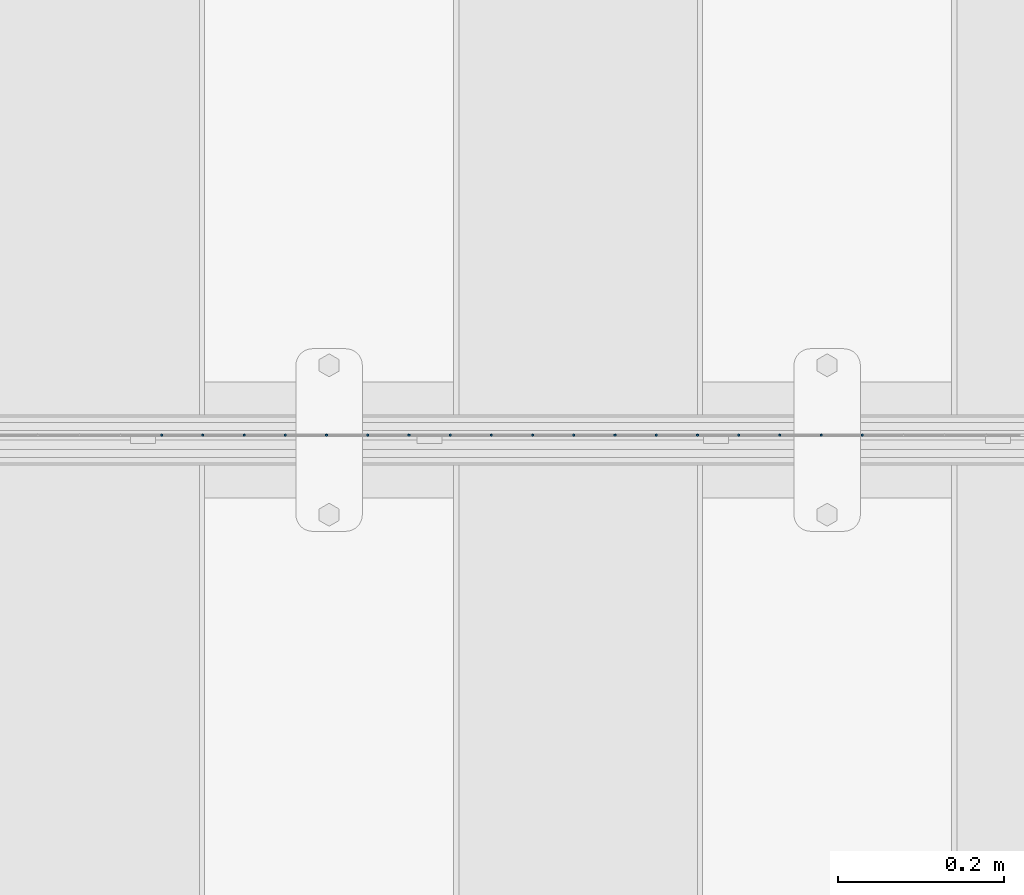
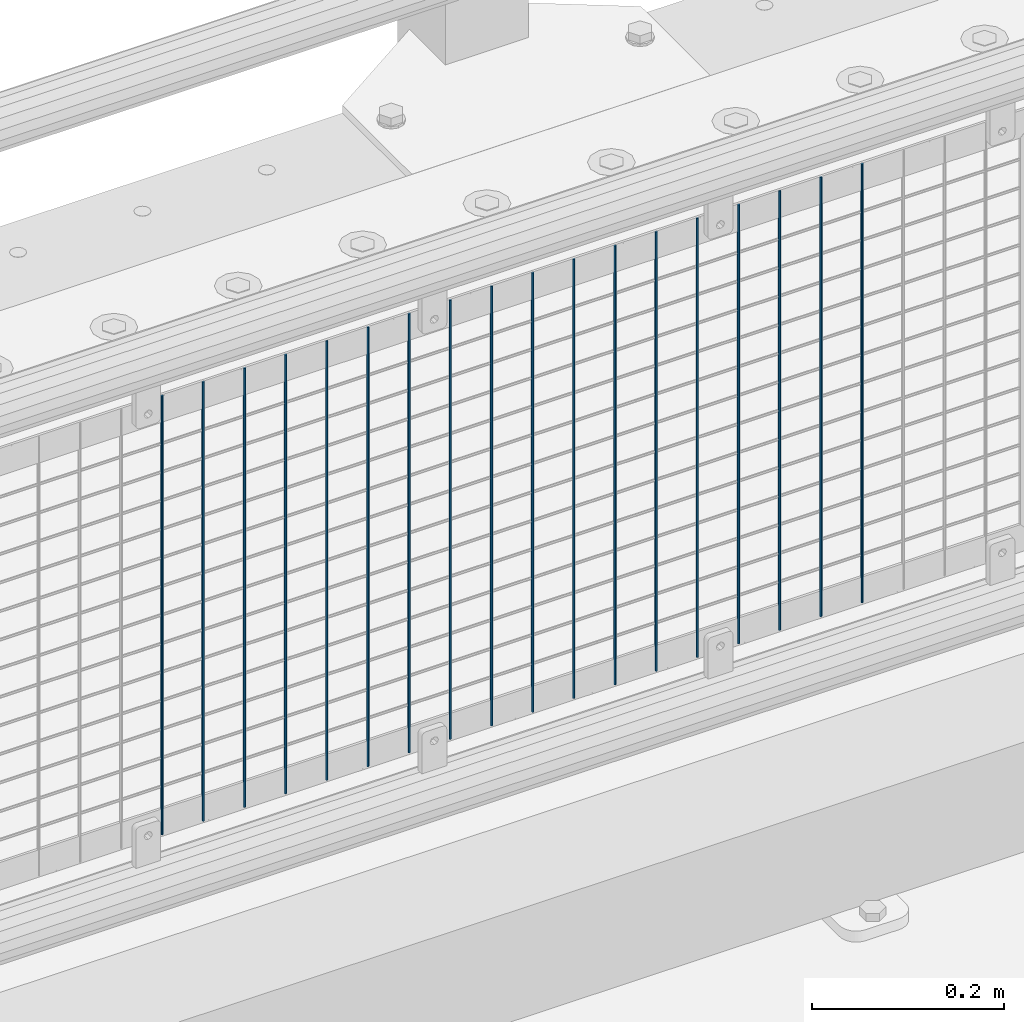
# One storey, part 69 of 247: 18 columns.
"""IFC2X3 building model written with IfcOpenShell, lengths in millimetres."""

from ifc_helpers import new_model, si_unit, frame, origin_with_axes, place, context, subcontext, project, spatial, faceted_brep, material, type_object, element, save


model = new_model("IFC2X3")

# Units and contexts
model_context = context("Model", 3, precision=1e-05, world=origin_with_axes())
body_context = subcontext(model_context, "Body", "Model", "MODEL_VIEW")
ifc_project = project(units=[si_unit("LENGTHUNIT", "METRE", prefix="MILLI"), si_unit("AREAUNIT", "SQUARE_METRE"), si_unit("VOLUMEUNIT", "CUBIC_METRE"), si_unit("MASSUNIT", "GRAM", prefix="KILO"), si_unit("TIMEUNIT", "SECOND"), si_unit("PLANEANGLEUNIT", "RADIAN"), si_unit("SOLIDANGLEUNIT", "STERADIAN"), si_unit("THERMODYNAMICTEMPERATUREUNIT", "DEGREE_CELSIUS"), si_unit("LUMINOUSINTENSITYUNIT", "LUMEN")], contexts=[model_context])

# Site, building, storey
site_placement = place(None, origin_with_axes())
site = spatial("IfcSite", under=ifc_project, at=site_placement, CompositionType="ELEMENT")
building_placement = place(site_placement, origin_with_axes())
building = spatial("IfcBuilding", under=site, at=building_placement, Name="Standard", CompositionType="ELEMENT")
storey_placement = place(building_placement, origin_with_axes())
storey = spatial("IfcBuildingStorey", under=building, at=storey_placement, Name="Undefined", CompositionType="ELEMENT", Elevation=0.0)

# Columns
ifc_material = material(Name="Misc_Undefined")
column_type = type_object("IfcColumnType", Name="D3", PredefinedType="NOTDEFINED")
for number, where, z_axis, x_axis in (
    (1, (1942.375, 7670.5, 353.02), (-1.0, 0.0, 0.0), (0.0, 0.0, 1.0)),
    (2, (1892.72, 7670.5, 353.02), (-1.0, 0.0, 0.0), (0.0, 0.0, 1.0)),
    (3, (1843.065, 7670.5, 353.02), (-1.0, 0.0, 0.0), (0.0, 0.0, 1.0)),
    (4, (1793.41, 7670.5, 353.02), (-1.0, 0.0, 0.0), (0.0, 0.0, 1.0)),
    (5, (1743.755, 7670.5, 353.02), (-1.0, 0.0, 0.0), (0.0, 0.0, 1.0)),
    (6, (1694.1, 7670.5, 353.02), (-1.0, 0.0, 0.0), (0.0, 0.0, 1.0)),
    (7, (1644.445, 7670.5, 353.02), (-1.0, 0.0, 0.0), (0.0, 0.0, 1.0)),
    (8, (1594.79, 7670.5, 353.02), (-1.0, 0.0, 0.0), (0.0, 0.0, 1.0)),
    (9, (1545.135, 7670.5, 353.02), (-1.0, 0.0, 0.0), (0.0, 0.0, 1.0)),
    (10, (1495.48, 7670.5, 353.02), (-1.0, 0.0, 0.0), (0.0, 0.0, 1.0)),
    (11, (1445.825, 7670.5, 353.02), (-1.0, 0.0, 0.0), (0.0, 0.0, 1.0)),
    (12, (1396.17, 7670.5, 353.02), (-1.0, 0.0, 0.0), (0.0, 0.0, 1.0)),
    (13, (1346.515, 7670.5, 353.02), (-1.0, 0.0, 0.0), (0.0, 0.0, 1.0)),
    (14, (1296.86, 7670.5, 353.02), (-1.0, 0.0, 0.0), (0.0, 0.0, 1.0)),
    (15, (1247.205, 7670.5, 353.02), (-1.0, 0.0, 0.0), (0.0, 0.0, 1.0)),
    (16, (1197.55, 7670.5, 353.02), (-1.0, 0.0, 0.0), (0.0, 0.0, 1.0)),
    (17, (1147.895, 7670.5, 353.02), (-1.0, 0.0, 0.0), (0.0, 0.0, 1.0)),
    (18, (1098.24, 7670.5, 353.02), (-1.0, 0.0, 0.0), (0.0, 0.0, 1.0)),
):
    element("IfcColumn", number, at=place(storey_placement, frame(where, z_axis=z_axis, x_axis=x_axis)), inside=storey, type_object=column_type, material=ifc_material, ObjectType="D3", context=body_context, shape_type="Brep", body=[
        faceted_brep([(1.81898940354586e-12, -1.5, -5.6843418860808e-14), (0.0, -0.75, -1.29903810567703), (560.0, -0.75, -1.29903810567703), (560.0, -1.5, 0.0), (0.0, 0.75, -1.29903810567703), (560.0, 0.75, -1.29903810567703), (1.81898940354586e-12, 1.5, -5.6843418860808e-14), (560.0, 1.5, 0.0), (0.0, 0.75, 1.29903810567703), (560.0, 0.75, 1.29903810567703), (0.0, -0.75, 1.29903810567703), (560.0, -0.75, 1.29903810567703)], [[[0, 1, 2, 3]], [[1, 4, 5, 2]], [[4, 6, 7, 5]], [[6, 8, 9, 7]], [[8, 10, 11, 9]], [[10, 0, 3, 11]], [[5, 7, 9, 11, 3, 2]], [[10, 8, 6, 4, 1, 0]]]),
    ])

save(model, "model.ifc")
